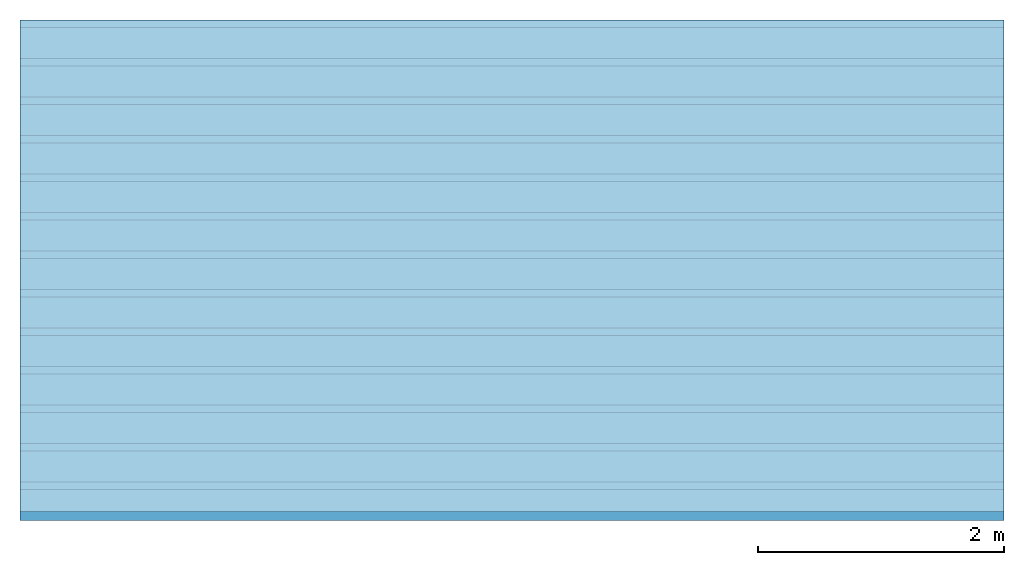
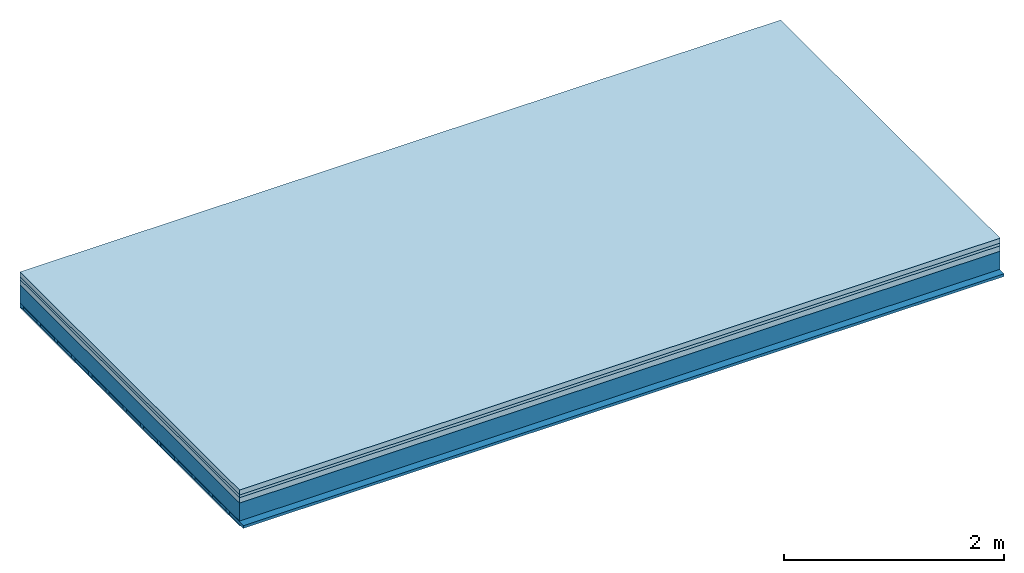
# One storey: 4 plates, 3 members, 1 element without a shape of its own.
"""IFC4 building model written with IfcOpenShell, lengths in metres."""

from ifc_helpers import new_model, si_unit, derived_unit, direction, frame, frame_2d, origin, origin_with_axes, place, context, project, spatial, rectangle, extrude, material, layer, layer_set, type_object, element, aggregate, save


model = new_model("IFC4")

# Units and contexts
plan_context = context("Plan", 3, precision=1e-05, world=origin(), true_north=direction((0.0, 1.0)))
model_context = context("Model", 3, precision=1e-05, world=origin(), true_north=direction((0.0, 1.0)))
ifc_project = project(units=[si_unit("LENGTHUNIT", "METRE"), derived_unit("SOUNDPRESSUREUNIT", [(si_unit("PRESSUREUNIT", "PASCAL", prefix="MICRO"), 0)]), si_unit("ENERGYUNIT", "JOULE", prefix="MEGA"), si_unit("MASSUNIT", "GRAM", prefix="KILO"), derived_unit("THERMALTRANSMITTANCEUNIT", [(si_unit("POWERUNIT", "WATT"), 1), (si_unit("AREAUNIT", "SQUARE_METRE"), -1), (si_unit("THERMODYNAMICTEMPERATUREUNIT", "KELVIN"), -1)]), derived_unit("AREADENSITYUNIT", [(si_unit("MASSUNIT", "GRAM", prefix="KILO"), 1), (si_unit("AREAUNIT", "SQUARE_METRE"), -1)]), derived_unit("USERDEFINED", [(si_unit("ENERGYUNIT", "JOULE", prefix="MEGA"), 1), (si_unit("AREAUNIT", "SQUARE_METRE"), -1)])], contexts=[plan_context, model_context])

# Site, building, storey
site = spatial("IfcSite", under=ifc_project)
building_placement = place(None, origin())
building = spatial("IfcBuilding", under=site, at=building_placement)
storey_placement = place(building_placement, origin())
storey = spatial("IfcBuildingStorey", under=building, at=storey_placement)

# Slab, members, plates
ifc_material_1 = material(Category="04.005")
ifc_layer_1 = layer(ifc_material_1, 0.055, Name="On-material")
ifc_material_2 = material()
ifc_layer_2 = layer(ifc_material_2, 0.03, Name="Impact sound insulation")
ifc_material_3 = material(Category="03.011")
ifc_layer_3 = layer(ifc_material_3, 0.06, Name="on Supporting structure")
ifc_layer_4 = layer(None, 0.2, Name="Supporting structure")
ifc_material_4 = material(Name="of the art")
ifc_layer_5 = layer(ifc_material_4, 0.0, Name="Bond")
ifc_layer_6 = layer(None, 0.04, Name="Battens / profiles")
ifc_material_5 = material(Category="03.007")
ifc_layer_7 = layer(ifc_material_5, 0.015, Name="Ceiling covering 1st layer")
ifc_material_6 = material(Name="Glued joints")
ifc_layer_8 = layer(ifc_material_6, 0.0, Name="Surface / treatment")
ifc_layer_set = layer_set([ifc_layer_1, ifc_layer_2, ifc_layer_3, ifc_layer_4, ifc_layer_5, ifc_layer_6, ifc_layer_7, ifc_layer_8])
slab_type = type_object("IfcSlabType", Name="A1110", PredefinedType="NOTDEFINED", material=ifc_layer_set)
slab_placement = place(None, frame((0.0, 0.0, 0.0), z_axis=(0.0, 0.0, -1.0), x_axis=(1.0, 0.0, 0.0)))
slab = element("IfcSlab", 1, at=slab_placement, inside=storey, type_object=slab_type, material=ifc_layer_set, Name="Slab #1")
ifc_material_7 = material()
member_1_placement = place(slab_placement, origin())
member_1 = element("IfcMember", 2, at=member_1_placement, material=ifc_material_7, Name="Supporting structure", context=plan_context, shape_type="SweptSolid", body=[
    extrude(rectangle(XDim=1.0, YDim=0.2, at=frame_2d((0.5, 0.1), x_axis=(1.0, 0.0))), frame((0.0, 4.0, 0.145), z_axis=(0.0, -1.0, 0.0), x_axis=(1.0, 0.0, 0.0)), (0.0, 0.0, 1.0), 4.0),
    extrude(rectangle(XDim=1.0, YDim=0.2, at=frame_2d((0.5, 0.1), x_axis=(1.0, 0.0))), frame((1.0, 4.0, 0.145), z_axis=(0.0, -1.0, 0.0), x_axis=(1.0, 0.0, 0.0)), (0.0, 0.0, 1.0), 4.0),
    extrude(rectangle(XDim=1.0, YDim=0.2, at=frame_2d((0.5, 0.1), x_axis=(1.0, 0.0))), frame((2.0, 4.0, 0.145), z_axis=(0.0, -1.0, 0.0), x_axis=(1.0, 0.0, 0.0)), (0.0, 0.0, 1.0), 4.0),
    extrude(rectangle(XDim=1.0, YDim=0.2, at=frame_2d((0.5, 0.1), x_axis=(1.0, 0.0))), frame((3.0, 4.0, 0.145), z_axis=(0.0, -1.0, 0.0), x_axis=(1.0, 0.0, 0.0)), (0.0, 0.0, 1.0), 4.0),
    extrude(rectangle(XDim=1.0, YDim=0.2, at=frame_2d((0.5, 0.1), x_axis=(1.0, 0.0))), frame((4.0, 4.0, 0.145), z_axis=(0.0, -1.0, 0.0), x_axis=(1.0, 0.0, 0.0)), (0.0, 0.0, 1.0), 4.0),
    extrude(rectangle(XDim=1.0, YDim=0.2, at=frame_2d((0.5, 0.1), x_axis=(1.0, 0.0))), frame((5.0, 4.0, 0.145), z_axis=(0.0, -1.0, 0.0), x_axis=(1.0, 0.0, 0.0)), (0.0, 0.0, 1.0), 4.0),
    extrude(rectangle(XDim=1.0, YDim=0.2, at=frame_2d((0.5, 0.1), x_axis=(1.0, 0.0))), frame((6.0, 4.0, 0.145), z_axis=(0.0, -1.0, 0.0), x_axis=(1.0, 0.0, 0.0)), (0.0, 0.0, 1.0), 4.0),
    extrude(rectangle(XDim=1.0, YDim=0.2, at=frame_2d((0.5, 0.1), x_axis=(1.0, 0.0))), frame((7.0, 4.0, 0.145), z_axis=(0.0, -1.0, 0.0), x_axis=(1.0, 0.0, 0.0)), (0.0, 0.0, 1.0), 4.0),
])
ifc_material_8 = material()
member_2_placement = place(slab_placement, origin())
member_2 = element("IfcMember", 3, at=member_2_placement, material=ifc_material_8, Name="Battens / profiles", context=plan_context, shape_type="SweptSolid", body=[
    extrude(rectangle(XDim=0.06, YDim=0.04, at=frame_2d((0.03, 0.02), x_axis=(1.0, 0.0))), frame((0.0, 0.0, 0.345), z_axis=(1.0, 0.0, 0.0), x_axis=(0.0, 1.0, 0.0)), (0.0, 0.0, 1.0), 8.0),
    extrude(rectangle(XDim=0.06, YDim=0.04, at=frame_2d((0.03, 0.02), x_axis=(1.0, 0.0))), frame((0.0, 0.313, 0.345), z_axis=(1.0, 0.0, 0.0), x_axis=(0.0, 1.0, 0.0)), (0.0, 0.0, 1.0), 8.0),
    extrude(rectangle(XDim=0.06, YDim=0.04, at=frame_2d((0.03, 0.02), x_axis=(1.0, 0.0))), frame((0.0, 0.626, 0.345), z_axis=(1.0, 0.0, 0.0), x_axis=(0.0, 1.0, 0.0)), (0.0, 0.0, 1.0), 8.0),
    extrude(rectangle(XDim=0.06, YDim=0.04, at=frame_2d((0.03, 0.02), x_axis=(1.0, 0.0))), frame((0.0, 0.939, 0.345), z_axis=(1.0, 0.0, 0.0), x_axis=(0.0, 1.0, 0.0)), (0.0, 0.0, 1.0), 8.0),
    extrude(rectangle(XDim=0.06, YDim=0.04, at=frame_2d((0.03, 0.02), x_axis=(1.0, 0.0))), frame((0.0, 1.252, 0.345), z_axis=(1.0, 0.0, 0.0), x_axis=(0.0, 1.0, 0.0)), (0.0, 0.0, 1.0), 8.0),
    extrude(rectangle(XDim=0.06, YDim=0.04, at=frame_2d((0.03, 0.02), x_axis=(1.0, 0.0))), frame((0.0, 1.565, 0.345), z_axis=(1.0, 0.0, 0.0), x_axis=(0.0, 1.0, 0.0)), (0.0, 0.0, 1.0), 8.0),
    extrude(rectangle(XDim=0.06, YDim=0.04, at=frame_2d((0.03, 0.02), x_axis=(1.0, 0.0))), frame((0.0, 1.878, 0.345), z_axis=(1.0, 0.0, 0.0), x_axis=(0.0, 1.0, 0.0)), (0.0, 0.0, 1.0), 8.0),
    extrude(rectangle(XDim=0.06, YDim=0.04, at=frame_2d((0.03, 0.02), x_axis=(1.0, 0.0))), frame((0.0, 2.191, 0.345), z_axis=(1.0, 0.0, 0.0), x_axis=(0.0, 1.0, 0.0)), (0.0, 0.0, 1.0), 8.0),
    extrude(rectangle(XDim=0.06, YDim=0.04, at=frame_2d((0.03, 0.02), x_axis=(1.0, 0.0))), frame((0.0, 2.504, 0.345), z_axis=(1.0, 0.0, 0.0), x_axis=(0.0, 1.0, 0.0)), (0.0, 0.0, 1.0), 8.0),
    extrude(rectangle(XDim=0.06, YDim=0.04, at=frame_2d((0.03, 0.02), x_axis=(1.0, 0.0))), frame((0.0, 2.817, 0.345), z_axis=(1.0, 0.0, 0.0), x_axis=(0.0, 1.0, 0.0)), (0.0, 0.0, 1.0), 8.0),
    extrude(rectangle(XDim=0.06, YDim=0.04, at=frame_2d((0.03, 0.02), x_axis=(1.0, 0.0))), frame((0.0, 3.13, 0.345), z_axis=(1.0, 0.0, 0.0), x_axis=(0.0, 1.0, 0.0)), (0.0, 0.0, 1.0), 8.0),
    extrude(rectangle(XDim=0.06, YDim=0.04, at=frame_2d((0.03, 0.02), x_axis=(1.0, 0.0))), frame((0.0, 3.443, 0.345), z_axis=(1.0, 0.0, 0.0), x_axis=(0.0, 1.0, 0.0)), (0.0, 0.0, 1.0), 8.0),
    extrude(rectangle(XDim=0.06, YDim=0.04, at=frame_2d((0.03, 0.02), x_axis=(1.0, 0.0))), frame((0.0, 3.756, 0.345), z_axis=(1.0, 0.0, 0.0), x_axis=(0.0, 1.0, 0.0)), (0.0, 0.0, 1.0), 8.0),
])
ifc_material_9 = material()
member_3_placement = place(slab_placement, origin())
member_3 = element("IfcMember", 4, at=member_3_placement, material=ifc_material_9, Name="Cavity", context=plan_context, shape_type="SweptSolid", body=[
    extrude(rectangle(XDim=0.253, YDim=0.03, at=frame_2d((0.1265, 0.015), x_axis=(1.0, 0.0))), frame((0.0, 0.06, 0.355), z_axis=(1.0, 0.0, 0.0), x_axis=(0.0, 1.0, 0.0)), (0.0, 0.0, 1.0), 8.0),
    extrude(rectangle(XDim=0.253, YDim=0.03, at=frame_2d((0.1265, 0.015), x_axis=(1.0, 0.0))), frame((0.0, 0.373, 0.355), z_axis=(1.0, 0.0, 0.0), x_axis=(0.0, 1.0, 0.0)), (0.0, 0.0, 1.0), 8.0),
    extrude(rectangle(XDim=0.253, YDim=0.03, at=frame_2d((0.1265, 0.015), x_axis=(1.0, 0.0))), frame((0.0, 0.686, 0.355), z_axis=(1.0, 0.0, 0.0), x_axis=(0.0, 1.0, 0.0)), (0.0, 0.0, 1.0), 8.0),
    extrude(rectangle(XDim=0.253, YDim=0.03, at=frame_2d((0.1265, 0.015), x_axis=(1.0, 0.0))), frame((0.0, 0.999, 0.355), z_axis=(1.0, 0.0, 0.0), x_axis=(0.0, 1.0, 0.0)), (0.0, 0.0, 1.0), 8.0),
    extrude(rectangle(XDim=0.253, YDim=0.03, at=frame_2d((0.1265, 0.015), x_axis=(1.0, 0.0))), frame((0.0, 1.312, 0.355), z_axis=(1.0, 0.0, 0.0), x_axis=(0.0, 1.0, 0.0)), (0.0, 0.0, 1.0), 8.0),
    extrude(rectangle(XDim=0.253, YDim=0.03, at=frame_2d((0.1265, 0.015), x_axis=(1.0, 0.0))), frame((0.0, 1.625, 0.355), z_axis=(1.0, 0.0, 0.0), x_axis=(0.0, 1.0, 0.0)), (0.0, 0.0, 1.0), 8.0),
    extrude(rectangle(XDim=0.253, YDim=0.03, at=frame_2d((0.1265, 0.015), x_axis=(1.0, 0.0))), frame((0.0, 1.938, 0.355), z_axis=(1.0, 0.0, 0.0), x_axis=(0.0, 1.0, 0.0)), (0.0, 0.0, 1.0), 8.0),
    extrude(rectangle(XDim=0.253, YDim=0.03, at=frame_2d((0.1265, 0.015), x_axis=(1.0, 0.0))), frame((0.0, 2.251, 0.355), z_axis=(1.0, 0.0, 0.0), x_axis=(0.0, 1.0, 0.0)), (0.0, 0.0, 1.0), 8.0),
    extrude(rectangle(XDim=0.253, YDim=0.03, at=frame_2d((0.1265, 0.015), x_axis=(1.0, 0.0))), frame((0.0, 2.564, 0.355), z_axis=(1.0, 0.0, 0.0), x_axis=(0.0, 1.0, 0.0)), (0.0, 0.0, 1.0), 8.0),
    extrude(rectangle(XDim=0.253, YDim=0.03, at=frame_2d((0.1265, 0.015), x_axis=(1.0, 0.0))), frame((0.0, 2.877, 0.355), z_axis=(1.0, 0.0, 0.0), x_axis=(0.0, 1.0, 0.0)), (0.0, 0.0, 1.0), 8.0),
    extrude(rectangle(XDim=0.253, YDim=0.03, at=frame_2d((0.1265, 0.015), x_axis=(1.0, 0.0))), frame((0.0, 3.19, 0.355), z_axis=(1.0, 0.0, 0.0), x_axis=(0.0, 1.0, 0.0)), (0.0, 0.0, 1.0), 8.0),
    extrude(rectangle(XDim=0.253, YDim=0.03, at=frame_2d((0.1265, 0.015), x_axis=(1.0, 0.0))), frame((0.0, 3.503, 0.355), z_axis=(1.0, 0.0, 0.0), x_axis=(0.0, 1.0, 0.0)), (0.0, 0.0, 1.0), 8.0),
    extrude(rectangle(XDim=0.253, YDim=0.03, at=frame_2d((0.1265, 0.015), x_axis=(1.0, 0.0))), frame((0.0, 3.816, 0.355), z_axis=(1.0, 0.0, 0.0), x_axis=(0.0, 1.0, 0.0)), (0.0, 0.0, 1.0), 8.0),
])
plate_1_placement = place(slab_placement, origin())
plate_1 = element("IfcPlate", 5, at=plate_1_placement, material=ifc_material_1, Name="On-material", context=plan_context, shape_type="SweptSolid", body=[
    extrude(rectangle(XDim=8.0, YDim=4.0, at=frame_2d((4.0, 2.0), x_axis=(1.0, 0.0))), origin_with_axes(), (0.0, 0.0, 1.0), 0.055),
])
plate_2_placement = place(slab_placement, origin())
plate_2 = element("IfcPlate", 6, at=plate_2_placement, material=ifc_material_2, Name="Impact sound insulation", context=plan_context, shape_type="SweptSolid", body=[
    extrude(rectangle(XDim=8.0, YDim=4.0, at=frame_2d((4.0, 2.0), x_axis=(1.0, 0.0))), frame((0.0, 0.0, 0.055), z_axis=(0.0, 0.0, 1.0), x_axis=(1.0, 0.0, 0.0)), (0.0, 0.0, 1.0), 0.03),
])
plate_3_placement = place(slab_placement, origin())
plate_3 = element("IfcPlate", 7, at=plate_3_placement, material=ifc_material_3, Name="on Supporting structure", context=plan_context, shape_type="SweptSolid", body=[
    extrude(rectangle(XDim=8.0, YDim=4.0, at=frame_2d((4.0, 2.0), x_axis=(1.0, 0.0))), frame((0.0, 0.0, 0.085), z_axis=(0.0, 0.0, 1.0), x_axis=(1.0, 0.0, 0.0)), (0.0, 0.0, 1.0), 0.06),
])
plate_4_placement = place(slab_placement, origin())
plate_4 = element("IfcPlate", 8, at=plate_4_placement, material=ifc_material_5, Name="Ceiling covering 1st layer", context=plan_context, shape_type="SweptSolid", body=[
    extrude(rectangle(XDim=8.0, YDim=4.0, at=frame_2d((4.0, 2.0), x_axis=(1.0, 0.0))), frame((0.0, 0.0, 0.385), z_axis=(0.0, 0.0, 1.0), x_axis=(1.0, 0.0, 0.0)), (0.0, 0.0, 1.0), 0.015),
])
aggregate(slab, [plate_1, plate_2, plate_3, member_1, member_2, member_3, plate_4])

save(model, "model.ifc")
